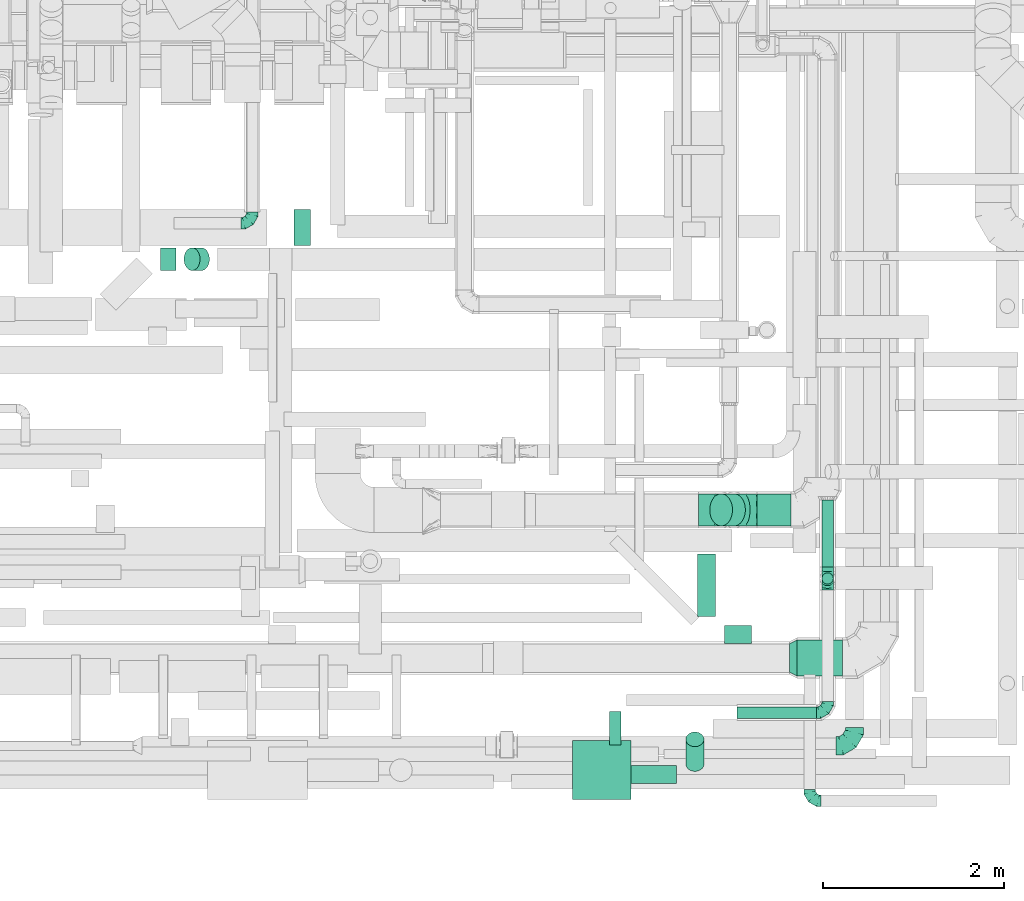
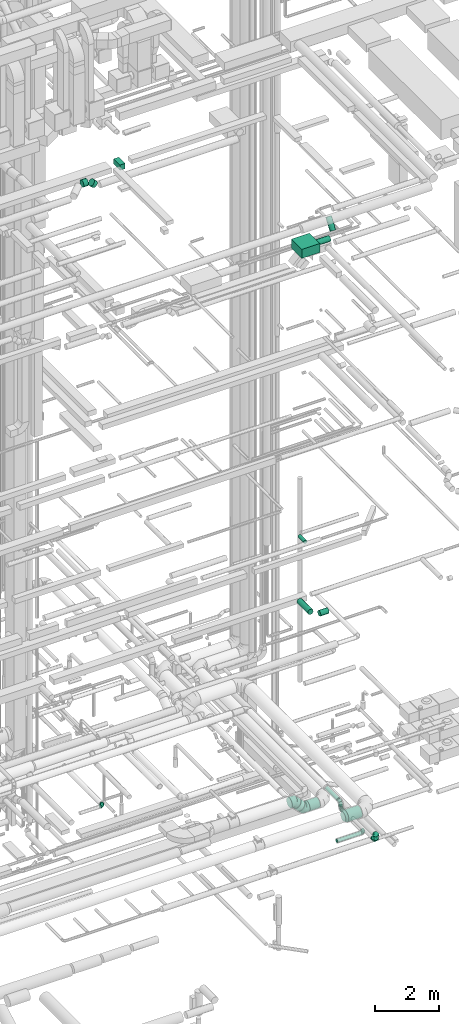
# One storey, part 211 of 337: 15 flow segments, 9 flow fittings.
"""IFC2X3 building model written with IfcOpenShell, lengths in millimetres."""

from ifc_helpers import new_model, entity, si_unit, converted_unit, derived_unit, direction, frame, origin, origin_2d_with_axis, place, context, subcontext, project, spatial, rectangle, circle, extrude, faceted_brep, source, transform, mapped, material, type_object, type_shapes, element, save


model = new_model("IFC2X3")

# Units and contexts
model_context = context("Model", 3, precision=0.01, world=origin(), true_north=direction((6.12303176911189e-17, 1.0)))
body_context = subcontext(model_context, "Body", "Model", "MODEL_VIEW")
ifc_project = project(units=[si_unit("LENGTHUNIT", "METRE", prefix="MILLI"), si_unit("AREAUNIT", "SQUARE_METRE"), si_unit("VOLUMEUNIT", "CUBIC_METRE"), converted_unit("PLANEANGLEUNIT", "DEGREE", entity("IfcRatioMeasure", 0.0174532925199433), si_unit("PLANEANGLEUNIT", "RADIAN"), dimensions=[0, 0, 0, 0, 0, 0, 0]), si_unit("MASSUNIT", "GRAM", prefix="KILO"), derived_unit("MASSDENSITYUNIT", [(si_unit("MASSUNIT", "GRAM", prefix="KILO"), 1), (si_unit("LENGTHUNIT", "METRE"), -3)]), derived_unit("MOMENTOFINERTIAUNIT", [(si_unit("LENGTHUNIT", "METRE"), 4)]), si_unit("TIMEUNIT", "SECOND"), si_unit("FREQUENCYUNIT", "HERTZ"), si_unit("THERMODYNAMICTEMPERATUREUNIT", "DEGREE_CELSIUS"), derived_unit("THERMALTRANSMITTANCEUNIT", [(si_unit("MASSUNIT", "GRAM", prefix="KILO"), 1), (si_unit("THERMODYNAMICTEMPERATUREUNIT", "KELVIN"), -1), (si_unit("TIMEUNIT", "SECOND"), -3)]), derived_unit("VOLUMETRICFLOWRATEUNIT", [(si_unit("LENGTHUNIT", "METRE"), 3), (si_unit("TIMEUNIT", "SECOND"), -1)]), derived_unit("MASSFLOWRATEUNIT", [(si_unit("MASSUNIT", "GRAM", prefix="KILO"), 1), (si_unit("TIMEUNIT", "SECOND"), -1)]), derived_unit("ROTATIONALFREQUENCYUNIT", [(si_unit("TIMEUNIT", "SECOND"), -1)]), si_unit("ELECTRICCURRENTUNIT", "AMPERE"), si_unit("ELECTRICVOLTAGEUNIT", "VOLT"), si_unit("POWERUNIT", "WATT"), si_unit("FORCEUNIT", "NEWTON", prefix="KILO"), si_unit("ILLUMINANCEUNIT", "LUX"), si_unit("LUMINOUSFLUXUNIT", "LUMEN"), si_unit("LUMINOUSINTENSITYUNIT", "CANDELA"), derived_unit("USERDEFINED", [(si_unit("MASSUNIT", "GRAM", prefix="KILO"), -1), (si_unit("LENGTHUNIT", "METRE"), -2), (si_unit("TIMEUNIT", "SECOND"), 3), (si_unit("LUMINOUSFLUXUNIT", "LUMEN"), 1)]), derived_unit("LINEARVELOCITYUNIT", [(si_unit("LENGTHUNIT", "METRE"), 1), (si_unit("TIMEUNIT", "SECOND"), -1)]), si_unit("PRESSUREUNIT", "PASCAL"), derived_unit("USERDEFINED", [(si_unit("LENGTHUNIT", "METRE"), -2), (si_unit("MASSUNIT", "GRAM", prefix="KILO"), 1), (si_unit("TIMEUNIT", "SECOND"), -2)]), derived_unit("LINEARFORCEUNIT", [(si_unit("MASSUNIT", "GRAM", prefix="KILO"), 1), (si_unit("LENGTHUNIT", "METRE"), 1), (si_unit("TIMEUNIT", "SECOND"), -2), (si_unit("LENGTHUNIT", "METRE"), -1)]), derived_unit("PLANARFORCEUNIT", [(si_unit("MASSUNIT", "GRAM", prefix="KILO"), 1), (si_unit("LENGTHUNIT", "METRE"), 1), (si_unit("TIMEUNIT", "SECOND"), -2), (si_unit("LENGTHUNIT", "METRE"), -2)])], contexts=[model_context])

# Site, building, storey
site_placement = place(None, origin())
site = spatial("IfcSite", under=ifc_project, at=site_placement, CompositionType="ELEMENT")
building_placement = place(site_placement, origin())
building = spatial("IfcBuilding", under=site, at=building_placement, CompositionType="ELEMENT")
storey_placement = place(building_placement, origin())
storey = spatial("IfcBuildingStorey", under=building, at=storey_placement, CompositionType="ELEMENT", Elevation=0.0)

# Flow segments
duct_segment_type_1 = type_object("IfcDuctSegmentType", PredefinedType="NOTDEFINED")
flow_segment_1_placement = place(storey_placement, frame((59849.57, 6380.41, 27450.0)))
element("IfcFlowSegment", 1, at=flow_segment_1_placement, inside=storey, type_object=duct_segment_type_1, context=body_context, shape_type="SweptSolid", body=[
    extrude(rectangle(XDim=180.199908000001, YDim=400.0, at=origin_2d_with_axis()), frame((90.1, 200.0, 0.0)), (0.0, 0.0, 1.0), 199.999999999998),
])
flow_segment_2_placement = place(storey_placement, frame((62917.37, 268.17, 26700.0)))
element("IfcFlowSegment", 2, at=flow_segment_2_placement, inside=storey, type_object=duct_segment_type_1, context=body_context, shape_type="SweptSolid", body=[
    extrude(rectangle(XDim=650.0, YDim=650.0, at=origin_2d_with_axis()), frame((325.0, 325.0, 0.0)), (0.0, 0.0, 1.0), 349.999999999998),
])
duct_segment_type_2 = type_object("IfcDuctSegmentType", PredefinedType="NOTDEFINED")
flow_segment_3_placement = place(storey_placement, frame((64597.18, 1986.28, 11298.4)))
element("IfcFlowSegment", 3, at=flow_segment_3_placement, inside=storey, type_object=duct_segment_type_2, context=body_context, shape_type="SweptSolid", body=[
    extrude(circle(Radius=100.0, at=origin_2d_with_axis()), frame((0.0, 101.6, 101.6), z_axis=(1.0, 0.0, 0.0), x_axis=(0.0, -1.0, 0.0)), (0.0, 0.0, 1.0), 299.999999999992),
])
flow_segment_4_placement = place(storey_placement, frame((64295.58, 2287.88, 11298.4)))
element("IfcFlowSegment", 4, at=flow_segment_4_placement, inside=storey, type_object=duct_segment_type_2, context=body_context, shape_type="SweptSolid", body=[
    extrude(circle(Radius=100.0, at=origin_2d_with_axis()), frame((101.6, 0.0, 101.6), z_axis=(0.0, 1.0, 0.0), x_axis=(-1.0, 0.0, 0.0)), (0.0, 0.0, 1.0), 690.000000000086),
])
flow_segment_5_placement = place(storey_placement, frame((63326.1, 870.66, 15235.9)))
element("IfcFlowSegment", 5, at=flow_segment_5_placement, inside=storey, type_object=duct_segment_type_2, context=body_context, shape_type="SweptSolid", body=[
    extrude(circle(Radius=62.5, at=origin_2d_with_axis()), frame((64.1, 0.0, 64.1), z_axis=(0.0, 1.0, 0.0), x_axis=(-1.0, 0.0, 0.0)), (0.0, 0.0, 1.0), 366.742634045055),
])
flow_segment_6_placement = place(storey_placement, frame((65398.97, 1627.77, 3298.4)))
element("IfcFlowSegment", 6, at=flow_segment_6_placement, inside=storey, type_object=duct_segment_type_2, context=body_context, shape_type="SweptSolid", body=[
    extrude(circle(Radius=200.0, at=origin_2d_with_axis()), frame((0.0, 201.6, 201.6), z_axis=(1.0, 0.0, 0.0), x_axis=(0.0, 1.0, 0.0)), (0.0, 0.0, 1.0), 499.999999999999),
])
flow_segment_7_placement = place(storey_placement, frame((65670.58, 2832.18, 3335.9)))
element("IfcFlowSegment", 7, at=flow_segment_7_placement, inside=storey, type_object=duct_segment_type_2, context=body_context, shape_type="SweptSolid", body=[
    extrude(circle(Radius=62.5, at=origin_2d_with_axis()), frame((64.1, 0.0, 64.1), z_axis=(0.0, 1.0, 0.0), x_axis=(1.0, 0.0, 0.0)), (0.0, 0.0, 1.0), 743.2794125909),
])
flow_segment_8_placement = place(storey_placement, frame((65670.58, 2643.09, 3265.0)))
element("IfcFlowSegment", 8, at=flow_segment_8_placement, inside=storey, type_object=duct_segment_type_2, context=body_context, shape_type="SweptSolid", body=[
    extrude(circle(Radius=62.5, at=origin_2d_with_axis()), frame((64.1, 64.1, 0.0)), (0.0, 0.0, 1.0), 10.0000000000416),
])
flow_segment_9_placement = place(storey_placement, frame((64734.68, 1163.09, 3075.9)))
element("IfcFlowSegment", 9, at=flow_segment_9_placement, inside=storey, type_object=duct_segment_type_2, context=body_context, shape_type="SweptSolid", body=[
    extrude(circle(Radius=62.5, at=origin_2d_with_axis()), frame((0.0, 64.1, 64.1), z_axis=(1.0, 0.0, 0.0), x_axis=(0.0, 1.0, 0.0)), (0.0, 0.0, 1.0), 875.0),
])
flow_segment_10_placement = place(storey_placement, frame((64952.5, 3285.06, 2870.9)))
element("IfcFlowSegment", 10, at=flow_segment_10_placement, inside=storey, type_object=duct_segment_type_2, context=body_context, shape_type="SweptSolid", body=[
    extrude(circle(Radius=177.5, at=origin_2d_with_axis()), frame((0.0, 179.1, 179.1), z_axis=(1.0, 0.0, 0.0), x_axis=(0.0, 1.0, 0.0)), (0.0, 0.0, 1.0), 375.734196684819),
])
flow_segment_11_placement = place(storey_placement, frame((64432.32, 3285.06, 3026.87)))
element("IfcFlowSegment", 11, at=flow_segment_11_placement, inside=storey, type_object=duct_segment_type_2, context=body_context, shape_type="SweptSolid", body=[
    extrude(circle(Radius=177.5, at=origin_2d_with_axis()), frame((127.11, 179.1, 269.15), z_axis=(0.707106792500257, 0.0, -0.707106769872838), x_axis=(0.0, -1.0, 0.0)), (0.0, 0.0, 1.0), 200.883132119856),
])
flow_segment_12_placement = place(storey_placement, frame((63567.37, 441.58, 26798.4)))
element("IfcFlowSegment", 12, at=flow_segment_12_placement, inside=storey, type_object=duct_segment_type_2, context=body_context, shape_type="SweptSolid", body=[
    extrude(circle(Radius=100.0, at=origin_2d_with_axis()), frame((0.0, 101.6, 101.6), z_axis=(1.0, 0.0, 0.0), x_axis=(0.0, -1.0, 0.0)), (0.0, 0.0, 1.0), 502.500000000024),
])
flow_segment_13_placement = place(storey_placement, frame((64168.27, 577.85, 27001.78)))
element("IfcFlowSegment", 13, at=flow_segment_13_placement, inside=storey, type_object=duct_segment_type_2, context=body_context, shape_type="SweptSolid", body=[
    extrude(circle(Radius=100.0, at=origin_2d_with_axis()), frame((101.6, 82.6, 60.23), z_axis=(0.0, 0.586367683700161, 0.810045023138905), x_axis=(-1.0, 0.0, 0.0)), (0.0, 0.0, 1.0), 464.149497873037),
])
flow_segment_14_placement = place(storey_placement, frame((58375.52, 6103.26, 27423.4)))
element("IfcFlowSegment", 14, at=flow_segment_14_placement, inside=storey, type_object=duct_segment_type_2, context=body_context, shape_type="SweptSolid", body=[
    extrude(circle(Radius=125.0, at=origin_2d_with_axis()), frame((0.0, 126.6, 126.6), z_axis=(1.0, 0.0, 0.0), x_axis=(0.0, 1.0, 0.0)), (0.0, 0.0, 1.0), 170.408739547255),
])
flow_segment_15_placement = place(storey_placement, frame((58632.72, 6103.26, 27283.24)))
element("IfcFlowSegment", 15, at=flow_segment_15_placement, inside=storey, type_object=duct_segment_type_2, context=body_context, shape_type="SweptSolid", body=[
    extrude(circle(Radius=125.0, at=origin_2d_with_axis()), frame((89.98, 126.6, 193.54), z_axis=(0.707106792500319, 0.0, -0.707106769872776), x_axis=(0.0, 1.0, 0.0)), (0.0, 0.0, 1.0), 146.446619749839),
])

# Flow fittings
ifc_material = material()
duct_fitting_type_1 = type_object("IfcDuctFittingType", PredefinedType="NOTDEFINED", material=ifc_material)
shared_shape_1 = source(origin(), body_context, "Body", "Brep", [
    faceted_brep([(-200.0, 0.0, -100.0), (-200.0, -25.88, -96.59), (-200.0, -50.0, -86.6), (-200.0, -70.71, -70.71), (-200.0, -86.6, -50.0), (-200.0, -96.59, -25.88), (-200.0, -100.0, 0.0), (-200.0, -96.59, 25.88), (-200.0, -86.6, 50.0), (-200.0, -70.71, 70.71), (-200.0, -50.0, 86.6), (-200.0, -25.88, 96.59), (-200.0, 0.0, 100.0), (-200.0, 25.88, 96.59), (-200.0, 50.0, 86.6), (-200.0, 70.71, 70.71), (-200.0, 86.6, 50.0), (-200.0, 96.59, 25.88), (-200.0, 100.0, 0.0), (-200.0, 96.59, -25.88), (-200.0, 86.6, -50.0), (-200.0, 70.71, -70.71), (-200.0, 50.0, -86.6), (-200.0, 25.88, -96.59), (-153.35, 25.88, 96.59), (-159.81, 50.0, 86.6), (-146.41, 0.0, 100.0), (-165.36, 70.71, 70.71), (-172.29, 96.59, 25.88), (-173.21, 100.0, 0.0), (-169.62, 86.6, 50.0), (-169.62, 86.6, -50.0), (-165.36, 70.71, -70.71), (-172.29, 96.59, -25.88), (-153.35, 25.88, -96.59), (-146.41, 0.0, -100.0), (-159.81, 50.0, -86.6), (-139.48, -25.88, -96.59), (-133.01, -50.0, -86.6), (-127.46, -70.71, -70.71), (-123.21, -86.6, -50.0), (-120.53, -96.59, -25.88), (-119.62, -100.0, 0.0), (-120.53, -96.59, 25.88), (-123.21, -86.6, 50.0), (-127.46, -70.71, 70.71), (-133.01, -50.0, 86.6), (-139.48, -25.88, 96.59), (-72.54, 72.54, 96.59), (-90.19, 90.19, 86.6), (-53.59, 53.59, 100.0), (-105.35, 105.35, 70.71), (-116.99, 116.99, 50.0), (-124.3, 124.3, 25.88), (-126.79, 126.79, 0.0), (-124.3, 124.3, -25.88), (-116.99, 116.99, -50.0), (-105.35, 105.35, -70.71), (-72.54, 72.54, -96.59), (-53.59, 53.59, -100.0), (-90.19, 90.19, -86.6), (-34.64, 34.64, -96.59), (-16.99, 16.99, -86.6), (-1.83, 1.83, -70.71), (9.81, -9.81, -50.0), (17.12, -17.12, -25.88), (19.62, -19.62, 0.0), (17.12, -17.12, 25.88), (9.81, -9.81, 50.0), (-1.83, 1.83, 70.71), (-16.99, 16.99, 86.6), (-34.64, 34.64, 96.59), (-25.88, 153.35, 96.59), (-50.0, 159.81, 86.6), (0.0, 146.41, 100.0), (-70.71, 165.36, 70.71), (-86.6, 169.62, 50.0), (-96.59, 172.29, 25.88), (-100.0, 173.21, 0.0), (-96.59, 172.29, -25.88), (-86.6, 169.62, -50.0), (-70.71, 165.36, -70.71), (-25.88, 153.35, -96.59), (0.0, 146.41, -100.0), (-50.0, 159.81, -86.6), (25.88, 139.48, -96.59), (50.0, 133.01, -86.6), (70.71, 127.46, -70.71), (86.6, 123.21, -50.0), (96.59, 120.53, -25.88), (100.0, 119.62, 0.0), (96.59, 120.53, 25.88), (86.6, 123.21, 50.0), (70.71, 127.46, 70.71), (50.0, 133.01, 86.6), (25.88, 139.48, 96.59), (-25.88, 200.0, -96.59), (-50.0, 200.0, -86.6), (-70.71, 200.0, -70.71), (-86.6, 200.0, -50.0), (-96.59, 200.0, -25.88), (-100.0, 200.0, 0.0), (-96.59, 200.0, 25.88), (-86.6, 200.0, 50.0), (-70.71, 200.0, 70.71), (-50.0, 200.0, 86.6), (-25.88, 200.0, 96.59), (0.0, 200.0, 100.0), (25.88, 200.0, 96.59), (50.0, 200.0, 86.6), (70.71, 200.0, 70.71), (86.6, 200.0, 50.0), (96.59, 200.0, 25.88), (100.0, 200.0, 0.0), (96.59, 200.0, -25.88), (86.6, 200.0, -50.0), (70.71, 200.0, -70.71), (50.0, 200.0, -86.6), (25.88, 200.0, -96.59), (0.0, 200.0, -100.0)], [[[0, 1, 2, 3, 4, 5, 6, 7, 8, 9, 10, 11, 12, 13, 14, 15, 16, 17, 18, 19, 20, 21, 22, 23]], [[24, 25, 14, 13]], [[26, 24, 13, 12]], [[14, 25, 27, 15]], [[28, 29, 18, 17]], [[30, 28, 17, 16]], [[15, 27, 30, 16]], [[20, 31, 32, 21]], [[33, 31, 20, 19]], [[18, 29, 33, 19]], [[34, 35, 0, 23]], [[36, 34, 23, 22]], [[32, 36, 22, 21]], [[1, 0, 35, 37]], [[2, 1, 37, 38]], [[38, 39, 3, 2]], [[5, 4, 40, 41]], [[6, 5, 41, 42]], [[39, 40, 4, 3]], [[6, 42, 43, 7]], [[7, 43, 44, 8]], [[8, 44, 45, 9]], [[9, 45, 46, 10]], [[10, 46, 47, 11]], [[26, 12, 11, 47]], [[48, 49, 25, 24]], [[50, 48, 24, 26]], [[27, 25, 49, 51]], [[52, 53, 28, 30]], [[51, 52, 30, 27]], [[29, 28, 53, 54]], [[55, 56, 31, 33]], [[54, 55, 33, 29]], [[32, 31, 56, 57]], [[58, 59, 35, 34]], [[60, 58, 34, 36]], [[57, 60, 36, 32]], [[37, 35, 59, 61]], [[38, 37, 61, 62]], [[39, 38, 62, 63]], [[41, 40, 64, 65]], [[42, 41, 65, 66]], [[63, 64, 40, 39]], [[43, 42, 66, 67]], [[44, 43, 67, 68]], [[68, 69, 45, 44]], [[46, 45, 69, 70]], [[47, 46, 70, 71]], [[26, 47, 71, 50]], [[72, 73, 49, 48]], [[74, 72, 48, 50]], [[51, 49, 73, 75]], [[76, 77, 53, 52]], [[75, 76, 52, 51]], [[54, 53, 77, 78]], [[79, 80, 56, 55]], [[78, 79, 55, 54]], [[57, 56, 80, 81]], [[82, 83, 59, 58]], [[84, 82, 58, 60]], [[81, 84, 60, 57]], [[61, 59, 83, 85]], [[62, 61, 85, 86]], [[63, 62, 86, 87]], [[65, 64, 88, 89]], [[66, 65, 89, 90]], [[87, 88, 64, 63]], [[67, 66, 90, 91]], [[68, 67, 91, 92]], [[92, 93, 69, 68]], [[70, 69, 93, 94]], [[71, 70, 94, 95]], [[50, 71, 95, 74]], [[96, 97, 98, 99, 100, 101, 102, 103, 104, 105, 106, 107, 108, 109, 110, 111, 112, 113, 114, 115, 116, 117, 118, 119]], [[72, 74, 107, 106]], [[73, 72, 106, 105]], [[75, 73, 105, 104]], [[102, 101, 78, 77]], [[103, 102, 77, 76]], [[75, 104, 103, 76]], [[78, 101, 100, 79]], [[79, 100, 99, 80]], [[80, 99, 98, 81]], [[84, 97, 96, 82]], [[82, 96, 119, 83]], [[84, 81, 98, 97]], [[118, 117, 86, 85]], [[119, 118, 85, 83]], [[116, 87, 86, 117]], [[88, 115, 114, 89]], [[89, 114, 113, 90]], [[115, 88, 87, 116]], [[91, 90, 113, 112]], [[92, 91, 112, 111]], [[111, 110, 93, 92]], [[95, 94, 109, 108]], [[74, 95, 108, 107]], [[110, 109, 94, 93]]]),
])
type_shapes(duct_fitting_type_1, [shared_shape_1])
flow_fitting_1_placement = place(storey_placement, frame((66029.36, 862.18, 3050.0)))
element("IfcFlowFitting", 16, at=flow_fitting_1_placement, inside=storey, type_object=duct_fitting_type_1, material=ifc_material, context=body_context, shape_type="MappedRepresentation", body=[
    mapped(shared_shape_1, transform((0.0, 0.0, 0.0), scale=1.0)),
])
duct_fitting_type_2 = type_object("IfcDuctFittingType", PredefinedType="NOTDEFINED", material=ifc_material)
shared_shape_2 = source(origin(), body_context, "Body", "Brep", [
    faceted_brep([(-125.0, 0.0, -62.5), (-125.0, -16.18, -60.37), (-125.0, -31.25, -54.13), (-125.0, -44.19, -44.19), (-125.0, -54.13, -31.25), (-125.0, -60.37, -16.18), (-125.0, -62.5, 0.0), (-125.0, -60.37, 16.18), (-125.0, -54.13, 31.25), (-125.0, -44.19, 44.19), (-125.0, -31.25, 54.13), (-125.0, -16.18, 60.37), (-125.0, 0.0, 62.5), (-125.0, 16.18, 60.37), (-125.0, 31.25, 54.13), (-125.0, 44.19, 44.19), (-125.0, 54.13, 31.25), (-125.0, 60.37, 16.18), (-125.0, 62.5, 0.0), (-125.0, 60.37, -16.18), (-125.0, 54.13, -31.25), (-125.0, 44.19, -44.19), (-125.0, 31.25, -54.13), (-125.0, 16.18, -60.37), (-95.84, 16.18, 60.37), (-99.88, 31.25, 54.13), (-91.51, 0.0, 62.5), (-103.35, 44.19, 44.19), (-107.68, 60.37, 16.18), (-108.25, 62.5, 0.0), (-106.01, 54.13, 31.25), (-106.01, 54.13, -31.25), (-103.35, 44.19, -44.19), (-107.68, 60.37, -16.18), (-95.84, 16.18, -60.37), (-91.51, 0.0, -62.5), (-99.88, 31.25, -54.13), (-87.17, -16.18, -60.37), (-83.13, -31.25, -54.13), (-79.66, -44.19, -44.19), (-77.0, -54.13, -31.25), (-75.33, -60.37, -16.18), (-74.76, -62.5, 0.0), (-75.33, -60.37, 16.18), (-77.0, -54.13, 31.25), (-79.66, -44.19, 44.19), (-83.13, -31.25, 54.13), (-87.17, -16.18, 60.37), (-45.34, 45.34, 60.37), (-56.37, 56.37, 54.13), (-33.49, 33.49, 62.5), (-65.85, 65.85, 44.19), (-73.12, 73.12, 31.25), (-77.69, 77.69, 16.18), (-79.25, 79.25, 0.0), (-77.69, 77.69, -16.18), (-73.12, 73.12, -31.25), (-65.85, 65.85, -44.19), (-45.34, 45.34, -60.37), (-33.49, 33.49, -62.5), (-56.37, 56.37, -54.13), (-21.65, 21.65, -60.37), (-10.62, 10.62, -54.13), (-1.14, 1.14, -44.19), (6.13, -6.13, -31.25), (10.7, -10.7, -16.18), (12.26, -12.26, 0.0), (10.7, -10.7, 16.18), (6.13, -6.13, 31.25), (-1.14, 1.14, 44.19), (-10.62, 10.62, 54.13), (-21.65, 21.65, 60.37), (-16.18, 95.84, 60.37), (-31.25, 99.88, 54.13), (0.0, 91.51, 62.5), (-44.19, 103.35, 44.19), (-54.13, 106.01, 31.25), (-60.37, 107.68, 16.18), (-62.5, 108.25, 0.0), (-60.37, 107.68, -16.18), (-54.13, 106.01, -31.25), (-44.19, 103.35, -44.19), (-16.18, 95.84, -60.37), (0.0, 91.51, -62.5), (-31.25, 99.88, -54.13), (16.18, 87.17, -60.37), (31.25, 83.13, -54.13), (44.19, 79.66, -44.19), (54.13, 77.0, -31.25), (60.37, 75.33, -16.18), (62.5, 74.76, 0.0), (60.37, 75.33, 16.18), (54.13, 77.0, 31.25), (44.19, 79.66, 44.19), (31.25, 83.13, 54.13), (16.18, 87.17, 60.37), (-16.18, 125.0, -60.37), (-31.25, 125.0, -54.13), (-44.19, 125.0, -44.19), (-54.13, 125.0, -31.25), (-60.37, 125.0, -16.18), (-62.5, 125.0, 0.0), (-60.37, 125.0, 16.18), (-54.13, 125.0, 31.25), (-44.19, 125.0, 44.19), (-31.25, 125.0, 54.13), (-16.18, 125.0, 60.37), (0.0, 125.0, 62.5), (16.18, 125.0, 60.37), (31.25, 125.0, 54.13), (44.19, 125.0, 44.19), (54.13, 125.0, 31.25), (60.37, 125.0, 16.18), (62.5, 125.0, 0.0), (60.37, 125.0, -16.18), (54.13, 125.0, -31.25), (44.19, 125.0, -44.19), (31.25, 125.0, -54.13), (16.18, 125.0, -60.37), (0.0, 125.0, -62.5)], [[[0, 1, 2, 3, 4, 5, 6, 7, 8, 9, 10, 11, 12, 13, 14, 15, 16, 17, 18, 19, 20, 21, 22, 23]], [[24, 25, 14, 13]], [[26, 24, 13, 12]], [[14, 25, 27, 15]], [[28, 29, 18, 17]], [[30, 28, 17, 16]], [[15, 27, 30, 16]], [[20, 31, 32, 21]], [[33, 31, 20, 19]], [[18, 29, 33, 19]], [[34, 35, 0, 23]], [[36, 34, 23, 22]], [[21, 32, 36, 22]], [[1, 0, 35, 37]], [[2, 1, 37, 38]], [[38, 39, 3, 2]], [[5, 4, 40, 41]], [[6, 5, 41, 42]], [[39, 40, 4, 3]], [[6, 42, 43, 7]], [[7, 43, 44, 8]], [[45, 9, 8, 44]], [[9, 45, 46, 10]], [[10, 46, 47, 11]], [[26, 12, 11, 47]], [[48, 49, 25, 24]], [[50, 48, 24, 26]], [[27, 25, 49, 51]], [[52, 53, 28, 30]], [[51, 52, 30, 27]], [[29, 28, 53, 54]], [[55, 56, 31, 33]], [[54, 55, 33, 29]], [[57, 32, 31, 56]], [[58, 59, 35, 34]], [[60, 58, 34, 36]], [[57, 60, 36, 32]], [[37, 35, 59, 61]], [[38, 37, 61, 62]], [[39, 38, 62, 63]], [[41, 40, 64, 65]], [[42, 41, 65, 66]], [[63, 64, 40, 39]], [[43, 42, 66, 67]], [[44, 43, 67, 68]], [[68, 69, 45, 44]], [[46, 45, 69, 70]], [[47, 46, 70, 71]], [[26, 47, 71, 50]], [[72, 73, 49, 48]], [[74, 72, 48, 50]], [[51, 49, 73, 75]], [[76, 77, 53, 52]], [[75, 76, 52, 51]], [[54, 53, 77, 78]], [[79, 80, 56, 55]], [[78, 79, 55, 54]], [[81, 57, 56, 80]], [[82, 83, 59, 58]], [[84, 82, 58, 60]], [[81, 84, 60, 57]], [[61, 59, 83, 85]], [[62, 61, 85, 86]], [[63, 62, 86, 87]], [[65, 64, 88, 89]], [[66, 65, 89, 90]], [[87, 88, 64, 63]], [[67, 66, 90, 91]], [[68, 67, 91, 92]], [[92, 93, 69, 68]], [[70, 69, 93, 94]], [[71, 70, 94, 95]], [[50, 71, 95, 74]], [[96, 97, 98, 99, 100, 101, 102, 103, 104, 105, 106, 107, 108, 109, 110, 111, 112, 113, 114, 115, 116, 117, 118, 119]], [[72, 74, 107, 106]], [[73, 72, 106, 105]], [[75, 73, 105, 104]], [[77, 76, 103, 102]], [[78, 77, 102, 101]], [[75, 104, 103, 76]], [[78, 101, 100, 79]], [[79, 100, 99, 80]], [[80, 99, 98, 81]], [[96, 119, 83, 82]], [[97, 96, 82, 84]], [[84, 81, 98, 97]], [[83, 119, 118, 85]], [[85, 118, 117, 86]], [[116, 87, 86, 117]], [[88, 115, 114, 89]], [[89, 114, 113, 90]], [[115, 88, 87, 116]], [[91, 90, 113, 112]], [[92, 91, 112, 111]], [[111, 110, 93, 92]], [[95, 94, 109, 108]], [[74, 95, 108, 107]], [[110, 109, 94, 93]]]),
])
type_shapes(duct_fitting_type_2, [shared_shape_2])
flow_fitting_2_placement = place(storey_placement, frame((59387.05, 6625.67, 3100.0)))
element("IfcFlowFitting", 17, at=flow_fitting_2_placement, inside=storey, type_object=duct_fitting_type_2, material=ifc_material, context=body_context, shape_type="MappedRepresentation", body=[
    mapped(shared_shape_2, transform((0.0, 0.0, 0.0), scale=1.0)),
])
for number, where, z_axis, x_axis in (
    (18, (65535.97, 254.37, 3500.0), (0.0, 0.0, 1.0), (0.0, -1.0, 0.0)),
    (19, (65734.68, 2707.18, 3140.0), (1.0, 0.0, 0.0), (0.0, 1.0, 0.0)),
    (20, (65734.68, 2707.18, 3400.0), (-1.0, 0.0, 0.0), (0.0, 0.0, 1.0)),
):
    element("IfcFlowFitting", number, at=place(storey_placement, frame(where, z_axis=z_axis, x_axis=x_axis)), inside=storey, type_object=duct_fitting_type_2, material=ifc_material, context=body_context, shape_type="MappedRepresentation", body=[
        mapped(shared_shape_2, transform((0.0, 0.0, 0.0), scale=1.0)),
    ])
flow_fitting_3_placement = place(storey_placement, frame((65734.68, 1227.18, 3140.0)))
element("IfcFlowFitting", 21, at=flow_fitting_3_placement, inside=storey, type_object=duct_fitting_type_2, material=ifc_material, context=body_context, shape_type="MappedRepresentation", body=[
    mapped(shared_shape_2, transform((0.0, 0.0, 0.0), scale=1.0)),
])
duct_fitting_type_3 = type_object("IfcDuctFittingType", PredefinedType="NOTDEFINED", material=ifc_material)
shared_shape_3 = source(origin(), body_context, "Body", "Brep", [
    faceted_brep([(85.0, 111.37, -111.37), (85.0, 136.4, -78.75), (85.0, 152.13, -40.76), (85.0, 157.5, 0.0), (85.0, 152.13, 40.76), (85.0, 136.4, 78.75), (85.0, 111.37, 111.37), (85.0, 78.75, 136.4), (85.0, 40.76, 152.13), (85.0, 0.0, 157.5), (85.0, -40.76, 152.13), (85.0, -78.75, 136.4), (85.0, -111.37, 111.37), (85.0, -136.4, 78.75), (85.0, -152.13, 40.76), (85.0, -157.5, 0.0), (85.0, -152.13, -40.76), (85.0, -136.4, -78.75), (85.0, -111.37, -111.37), (85.0, -78.75, -136.4), (85.0, -40.76, -152.13), (85.0, 0.0, -157.5), (85.0, 40.76, -152.13), (85.0, 78.75, -136.4), (0.0, -200.0, 0.0), (0.0, -194.99, 44.5), (0.0, -180.19, 86.78), (0.0, -156.37, 124.7), (0.0, -124.7, 156.37), (0.0, -86.78, 180.19), (0.0, -44.5, 194.99), (0.0, 0.0, 200.0), (0.0, 44.5, 194.99), (0.0, 86.78, 180.19), (0.0, 124.7, 156.37), (0.0, 156.37, 124.7), (0.0, 180.19, 86.78), (0.0, 194.99, 44.5), (0.0, 200.0, 0.0), (0.0, 194.99, -44.5), (0.0, 180.19, -86.78), (0.0, 156.37, -124.7), (0.0, 124.7, -156.37), (0.0, 86.78, -180.19), (0.0, 44.5, -194.99), (0.0, 0.0, -200.0), (0.0, -44.5, -194.99), (0.0, -86.78, -180.19), (0.0, -124.7, -156.37), (0.0, -156.37, -124.7), (0.0, -180.19, -86.78), (0.0, -194.99, -44.5)], [[[0, 1, 2, 3, 4, 5, 6, 7, 8, 9, 10, 11, 12, 13, 14, 15, 16, 17, 18, 19, 20, 21, 22, 23]], [[24, 25, 26, 27, 28, 29, 30, 31, 32, 33, 34, 35, 36, 37, 38, 39, 40, 41, 42, 43, 44, 45, 46, 47, 48, 49, 50, 51]], [[8, 7, 33]], [[9, 8, 32]], [[31, 9, 32]], [[32, 8, 33]], [[7, 34, 33]], [[7, 6, 34]], [[35, 6, 5]], [[4, 3, 37]], [[36, 5, 4]], [[36, 35, 5]], [[37, 36, 4]], [[3, 38, 37]], [[6, 35, 34]], [[14, 13, 26]], [[15, 14, 25]], [[24, 15, 25]], [[25, 14, 26]], [[13, 27, 26]], [[13, 12, 27]], [[28, 12, 11]], [[10, 9, 30]], [[29, 11, 10]], [[29, 28, 11]], [[30, 29, 10]], [[9, 31, 30]], [[12, 28, 27]], [[20, 19, 47]], [[21, 20, 46]], [[45, 21, 46]], [[46, 20, 47]], [[19, 48, 47]], [[19, 18, 48]], [[49, 18, 17]], [[16, 15, 51]], [[50, 17, 16]], [[50, 49, 17]], [[51, 50, 16]], [[15, 24, 51]], [[18, 49, 48]], [[2, 1, 40]], [[3, 2, 39]], [[38, 3, 39]], [[39, 2, 40]], [[1, 41, 40]], [[1, 0, 41]], [[42, 0, 23]], [[22, 21, 44]], [[43, 23, 22]], [[43, 42, 23]], [[44, 43, 22]], [[21, 45, 44]], [[0, 42, 41]]]),
])
type_shapes(duct_fitting_type_3, [shared_shape_3])
flow_fitting_4_placement = place(storey_placement, frame((65398.97, 1829.37, 3500.0), z_axis=(0.0, 0.0, 1.0), x_axis=(-1.0, 0.0, 0.0)))
element("IfcFlowFitting", 22, at=flow_fitting_4_placement, inside=storey, type_object=duct_fitting_type_3, material=ifc_material, context=body_context, shape_type="MappedRepresentation", body=[
    mapped(shared_shape_3, transform((0.0, 0.0, 0.0), scale=1.0)),
])
duct_fitting_type_4 = type_object("IfcDuctFittingType", PredefinedType="NOTDEFINED", material=ifc_material)
shared_shape_4 = source(origin(), body_context, "Body", "Brep", [
    faceted_brep([(-147.05, 0.0, -177.5), (-147.05, -45.94, -171.45), (-147.05, -88.75, -153.72), (-147.05, -125.51, -125.51), (-147.05, -153.72, -88.75), (-147.05, -171.45, -45.94), (-147.05, -177.5, 0.0), (-147.05, -171.45, 45.94), (-147.05, -153.72, 88.75), (-147.05, -125.51, 125.51), (-147.05, -88.75, 153.72), (-147.05, -45.94, 171.45), (-147.05, 0.0, 177.5), (-147.05, 45.94, 171.45), (-147.05, 88.75, 153.72), (-147.05, 125.51, 125.51), (-147.05, 153.72, 88.75), (-147.05, 171.45, 45.94), (-147.05, 177.5, 0.0), (-147.05, 171.45, -45.94), (-147.05, 153.72, -88.75), (-147.05, 125.51, -125.51), (-147.05, 88.75, -153.72), (-147.05, 45.94, -171.45), (-16.36, 39.5, 173.05), (-31.9, 77.01, 159.92), (0.0, 0.0, 177.5), (-45.84, 110.67, 138.78), (-57.48, 138.78, 110.67), (-66.24, 159.92, 77.01), (-71.68, 173.05, 39.5), (-73.52, 177.5, 0.0), (-66.24, 159.92, -77.01), (-57.48, 138.78, -110.67), (-71.68, 173.05, -39.5), (-45.84, 110.67, -138.78), (-31.9, 77.01, -159.92), (-16.36, 39.5, -173.05), (0.0, 0.0, -177.5), (16.36, -39.5, -173.05), (31.9, -77.01, -159.92), (45.84, -110.67, -138.78), (57.48, -138.78, -110.67), (66.24, -159.92, -77.01), (71.68, -173.05, -39.5), (73.52, -177.5, 0.0), (71.68, -173.05, 39.5), (66.24, -159.92, 77.01), (57.48, -138.78, 110.67), (45.84, -110.67, 138.78), (31.9, -77.01, 159.92), (16.36, -39.5, 173.05), (103.98, 103.98, 177.5), (71.49, 136.46, 171.45), (41.22, 166.73, 153.72), (15.23, 192.73, 125.51), (-4.72, 212.67, 88.75), (-17.26, 225.21, 45.94), (-21.53, 229.49, 0.0), (-17.26, 225.21, -45.94), (-4.72, 212.67, -88.75), (15.23, 192.73, -125.51), (41.22, 166.73, -153.72), (71.49, 136.46, -171.45), (103.98, 103.98, -177.5), (136.46, 71.49, -171.45), (166.73, 41.22, -153.72), (192.73, 15.23, -125.51), (212.67, -4.72, -88.75), (225.21, -17.26, -45.94), (229.49, -21.53, 0.0), (225.21, -17.26, 45.94), (212.67, -4.72, 88.75), (192.73, 15.23, 125.51), (166.73, 41.22, 153.72), (136.46, 71.49, 171.45)], [[[0, 1, 2, 3, 4, 5, 6, 7, 8, 9, 10, 11, 12, 13, 14, 15, 16, 17, 18, 19, 20, 21, 22, 23]], [[24, 25, 13]], [[26, 24, 12]], [[12, 24, 13]], [[14, 27, 15]], [[14, 13, 25]], [[27, 14, 25]], [[28, 29, 16]], [[30, 31, 18]], [[29, 30, 17]], [[15, 28, 16]], [[16, 29, 17]], [[30, 18, 17]], [[28, 15, 27]], [[32, 33, 20]], [[34, 32, 19]], [[31, 34, 18]], [[18, 34, 19]], [[32, 20, 19]], [[33, 21, 20]], [[35, 36, 22]], [[37, 38, 0]], [[36, 37, 23]], [[21, 35, 22]], [[22, 36, 23]], [[37, 0, 23]], [[35, 21, 33]], [[1, 39, 40]], [[2, 40, 41]], [[38, 39, 0]], [[0, 39, 1]], [[40, 2, 1]], [[41, 3, 2]], [[4, 42, 43]], [[43, 44, 5]], [[45, 6, 44]], [[3, 42, 4]], [[4, 43, 5]], [[44, 6, 5]], [[42, 3, 41]], [[6, 45, 46]], [[7, 46, 47]], [[6, 46, 7]], [[8, 48, 9]], [[8, 7, 47]], [[48, 8, 47]], [[10, 49, 50]], [[11, 50, 51]], [[12, 51, 26]], [[9, 49, 10]], [[10, 50, 11]], [[51, 12, 11]], [[49, 9, 48]], [[24, 52, 53]], [[25, 53, 54]], [[24, 26, 52]], [[27, 25, 54]], [[24, 53, 25]], [[54, 55, 27]], [[28, 55, 56]], [[29, 56, 57]], [[30, 57, 58]], [[29, 28, 56]], [[31, 30, 58]], [[29, 57, 30]], [[55, 28, 27]], [[59, 60, 32]], [[58, 59, 34]], [[34, 31, 58]], [[33, 32, 60]], [[34, 59, 32]], [[60, 61, 33]], [[35, 61, 62]], [[36, 62, 63]], [[37, 63, 64]], [[36, 35, 62]], [[38, 37, 64]], [[36, 63, 37]], [[61, 35, 33]], [[39, 64, 65]], [[40, 65, 66]], [[38, 64, 39]], [[40, 39, 65]], [[41, 40, 66]], [[66, 67, 41]], [[42, 67, 68]], [[43, 68, 69]], [[44, 69, 70]], [[42, 68, 43]], [[44, 43, 69]], [[45, 44, 70]], [[67, 42, 41]], [[46, 70, 71]], [[47, 71, 72]], [[45, 70, 46]], [[46, 71, 47]], [[72, 48, 47]], [[72, 73, 48]], [[49, 73, 74]], [[50, 74, 75]], [[51, 75, 52]], [[49, 74, 50]], [[50, 75, 51]], [[52, 26, 51]], [[73, 49, 48]], [[63, 62, 61, 60, 59, 58, 57, 56, 55, 54, 53, 52, 75, 74, 73, 72, 71, 70, 69, 68, 67, 66, 65, 64]]]),
])
type_shapes(duct_fitting_type_4, [shared_shape_4])
for number, where, z_axis, x_axis in (
    (23, (64455.45, 3464.15, 3400.0), (0.0, 1.0, 0.0), (1.0, 0.0, 0.0)),
    (24, (64805.45, 3464.15, 3050.0), (0.0, -1.0, 0.0), (0.707106792500217, 0.0, -0.707106769872878)),
):
    element("IfcFlowFitting", number, at=place(storey_placement, frame(where, z_axis=z_axis, x_axis=x_axis)), inside=storey, type_object=duct_fitting_type_4, material=ifc_material, context=body_context, shape_type="MappedRepresentation", body=[
        mapped(shared_shape_4, transform((0.0, 0.0, 0.0), scale=1.0)),
    ])

save(model, "model.ifc")
